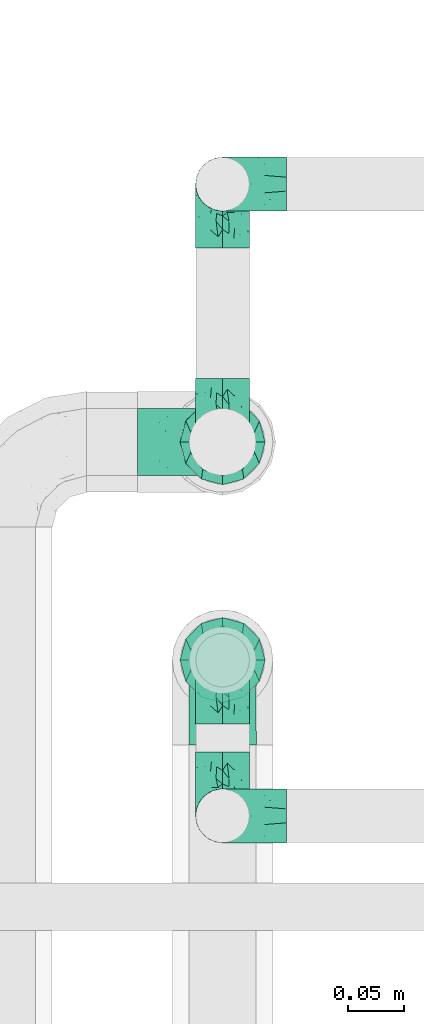
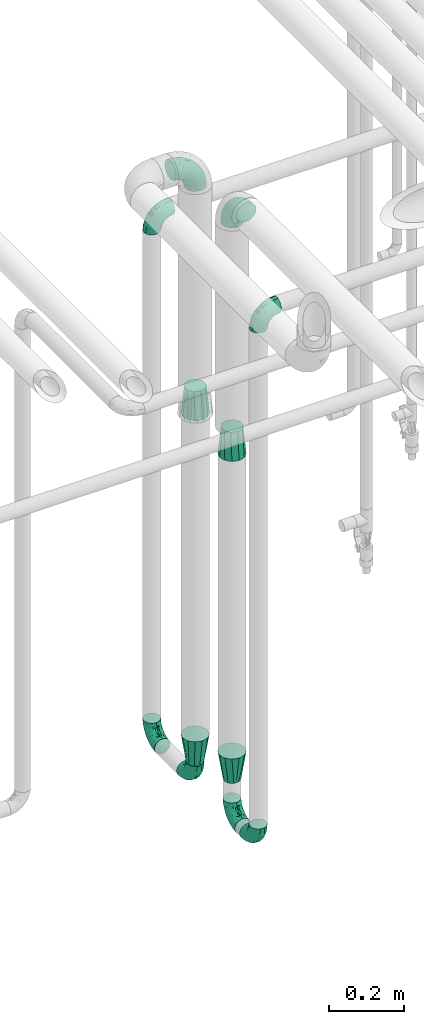
# One storey, part 576 of 827: 12 flow fittings.
"""IFC2X3 building model written with IfcOpenShell, lengths in millimetres."""

from ifc_helpers import new_model, entity, si_unit, converted_unit, derived_unit, direction, frame, origin, place, context, subcontext, project, spatial, faceted_brep, source, transform, mapped, material, type_object, type_shapes, element, save


model = new_model("IFC2X3")

# Units and contexts
model_context = context("Model", 3, precision=0.01, world=origin(), true_north=direction((6.12303176911189e-17, 1.0)))
body_context = subcontext(model_context, "Body", "Model", "MODEL_VIEW")
ifc_project = project(units=[si_unit("LENGTHUNIT", "METRE", prefix="MILLI"), si_unit("AREAUNIT", "SQUARE_METRE"), si_unit("VOLUMEUNIT", "CUBIC_METRE"), converted_unit("PLANEANGLEUNIT", "DEGREE", entity("IfcRatioMeasure", 0.0174532925199433), si_unit("PLANEANGLEUNIT", "RADIAN"), dimensions=[0, 0, 0, 0, 0, 0, 0]), si_unit("MASSUNIT", "GRAM", prefix="KILO"), derived_unit("MASSDENSITYUNIT", [(si_unit("MASSUNIT", "GRAM", prefix="KILO"), 1), (si_unit("LENGTHUNIT", "METRE"), -3)]), derived_unit("MOMENTOFINERTIAUNIT", [(si_unit("LENGTHUNIT", "METRE"), 4)]), si_unit("TIMEUNIT", "SECOND"), si_unit("FREQUENCYUNIT", "HERTZ"), si_unit("THERMODYNAMICTEMPERATUREUNIT", "DEGREE_CELSIUS"), derived_unit("THERMALTRANSMITTANCEUNIT", [(si_unit("MASSUNIT", "GRAM", prefix="KILO"), 1), (si_unit("THERMODYNAMICTEMPERATUREUNIT", "KELVIN"), -1), (si_unit("TIMEUNIT", "SECOND"), -3)]), derived_unit("VOLUMETRICFLOWRATEUNIT", [(si_unit("LENGTHUNIT", "METRE"), 3), (si_unit("TIMEUNIT", "SECOND"), -1)]), derived_unit("MASSFLOWRATEUNIT", [(si_unit("MASSUNIT", "GRAM", prefix="KILO"), 1), (si_unit("TIMEUNIT", "SECOND"), -1)]), derived_unit("ROTATIONALFREQUENCYUNIT", [(si_unit("TIMEUNIT", "SECOND"), -1)]), si_unit("ELECTRICCURRENTUNIT", "AMPERE"), si_unit("ELECTRICVOLTAGEUNIT", "VOLT"), si_unit("POWERUNIT", "WATT"), si_unit("FORCEUNIT", "NEWTON", prefix="KILO"), si_unit("ILLUMINANCEUNIT", "LUX"), si_unit("LUMINOUSFLUXUNIT", "LUMEN"), si_unit("LUMINOUSINTENSITYUNIT", "CANDELA"), derived_unit("USERDEFINED", [(si_unit("MASSUNIT", "GRAM", prefix="KILO"), -1), (si_unit("LENGTHUNIT", "METRE"), -2), (si_unit("TIMEUNIT", "SECOND"), 3), (si_unit("LUMINOUSFLUXUNIT", "LUMEN"), 1)]), derived_unit("LINEARVELOCITYUNIT", [(si_unit("LENGTHUNIT", "METRE"), 1), (si_unit("TIMEUNIT", "SECOND"), -1)]), si_unit("PRESSUREUNIT", "PASCAL"), derived_unit("USERDEFINED", [(si_unit("LENGTHUNIT", "METRE"), -2), (si_unit("MASSUNIT", "GRAM", prefix="KILO"), 1), (si_unit("TIMEUNIT", "SECOND"), -2)]), derived_unit("LINEARFORCEUNIT", [(si_unit("MASSUNIT", "GRAM", prefix="KILO"), 1), (si_unit("LENGTHUNIT", "METRE"), 1), (si_unit("TIMEUNIT", "SECOND"), -2), (si_unit("LENGTHUNIT", "METRE"), -1)]), derived_unit("PLANARFORCEUNIT", [(si_unit("MASSUNIT", "GRAM", prefix="KILO"), 1), (si_unit("LENGTHUNIT", "METRE"), 1), (si_unit("TIMEUNIT", "SECOND"), -2), (si_unit("LENGTHUNIT", "METRE"), -2)])], contexts=[model_context])

# Site, building, storey
site_placement = place(None, origin())
site = spatial("IfcSite", under=ifc_project, at=site_placement, CompositionType="ELEMENT")
building_placement = place(site_placement, origin())
building = spatial("IfcBuilding", under=site, at=building_placement, CompositionType="ELEMENT")
storey_placement = place(building_placement, frame((0.0, 0.0, 28200.0)))
storey = spatial("IfcBuildingStorey", under=building, at=storey_placement, Name="08", CompositionType="ELEMENT", Elevation=28200.0)

# Flow fittings
ifc_material = material()
pipe_fitting_type_1 = type_object("IfcPipeFittingType", Name="ADSK_1", PredefinedType="NOTDEFINED", material=ifc_material)
shared_shape_1 = source(origin(), body_context, "Body", "Brep", [
    faceted_brep([(-57.0, 12.07, -20.91), (-57.0, 6.25, -23.33), (-57.0, 0.0, -24.15), (-57.0, -6.25, -23.33), (-57.0, -12.08, -20.91), (-57.0, -17.08, -17.08), (-57.0, -20.91, -12.08), (-57.0, -23.33, -6.25), (-57.0, -24.15, 0.0), (-57.0, -23.33, 6.25), (-57.0, -20.91, 12.07), (-57.0, -17.08, 17.08), (-57.0, -12.08, 20.91), (-57.0, -6.25, 23.33), (-57.0, 0.0, 24.15), (-57.0, 6.25, 23.33), (-57.0, 12.07, 20.91), (-57.0, 17.08, 17.08), (-57.0, 20.91, 12.07), (-57.0, 23.33, 6.25), (-57.0, 24.15, 0.0), (-57.0, 23.33, -6.25), (-57.0, 20.91, -12.08), (-57.0, 17.08, -17.08), (0.0, 57.0, -24.15), (-6.25, 57.0, -23.33), (-12.07, 57.0, -20.91), (-17.08, 57.0, -17.08), (-20.91, 57.0, -12.08), (-23.33, 57.0, -6.25), (-24.15, 57.0, 0.0), (-23.33, 57.0, 6.25), (-20.91, 57.0, 12.07), (-17.08, 57.0, 17.08), (-12.07, 57.0, 20.91), (-6.25, 57.0, 23.33), (0.0, 57.0, 24.15), (6.25, 57.0, 23.33), (12.08, 57.0, 20.91), (17.08, 57.0, 17.08), (20.91, 57.0, 12.07), (23.33, 57.0, 6.25), (24.15, 57.0, 0.0), (23.33, 57.0, -6.25), (20.91, 57.0, -12.08), (17.08, 57.0, -17.08), (12.08, 57.0, -20.91), (6.25, 57.0, -23.33), (14.9, 21.14, 6.17), (13.61, 24.64, 12.48), (6.23, 8.95, 8.98), (-41.47, -21.06, 0.0), (-41.92, -18.38, 13.72), (-24.64, -13.61, 12.48), (-37.37, -13.24, 18.15), (-6.8, -4.93, 8.18), (-21.76, -15.19, 6.22), (-12.78, -9.18, 0.0), (-37.73, -20.51, 7.75), (-7.38, 7.38, 20.24), (-23.37, -4.26, 20.42), (-11.9, -3.19, 15.86), (-42.14, -8.7, 21.82), (13.24, 37.37, 18.15), (9.33, 23.53, 16.85), (4.26, 23.37, 20.42), (2.77, 10.92, 15.55), (-29.46, 0.91, 23.52), (-44.13, 20.56, 15.69), (-39.25, 26.33, 10.88), (-49.02, 22.92, 9.96), (-34.58, 23.87, 17.15), (-15.8, 6.8, 22.81), (-8.67, 20.47, 23.88), (-18.12, 12.9, 24.08), (-48.29, 14.92, 19.65), (-44.06, -2.85, 23.78), (-9.23, 48.95, 22.58), (-3.78, 42.74, 24.07), (-40.34, 4.26, 24.09), (-44.02, 26.14, 5.46), (-44.04, 9.88, 22.74), (-4.95, 16.87, 22.52), (-2.75, 1.43, 12.5), (-25.48, 40.98, 10.71), (20.51, 37.73, 7.75), (18.38, 41.92, 13.72), (8.7, 42.14, 21.82), (-25.95, -17.97, 0.0), (2.85, 44.06, 23.78), (21.06, 41.47, 0.0), (17.97, 25.95, 0.0), (-24.04, -9.27, 17.13), (-33.26, 33.26, 5.86), (-28.55, 40.57, 0.0), (-40.57, 28.55, 0.0), (-25.29, 47.19, 4.06), (-27.01, 31.1, 16.77), (-15.7, 43.95, 19.9), (-20.27, 45.22, 15.61), (-30.53, 31.98, 12.64), (-11.28, 38.33, 22.92), (-9.97, 27.88, 24.09), (-20.15, 30.26, 21.25), (-31.25, 11.75, 23.64), (-28.75, 7.23, 24.15), (-29.53, 18.06, 22.27), (-28.44, 24.21, 20.02), (-37.55, 17.7, 20.26), (-15.88, 29.25, 22.99), (-20.82, 20.82, 23.44), (-0.91, 29.46, 23.52), (-13.5, -7.67, 12.04), (1.49, 1.56, 5.16), (8.86, 10.35, 4.59), (0.38, -0.38, 0.0), (9.18, 12.78, 0.0), (-37.37, -13.24, -18.15), (8.86, 10.35, -4.59), (-45.22, 20.27, -15.61), (-43.95, 15.7, -19.9), (-38.33, 11.28, -22.92), (-48.95, 9.23, -22.58), (-47.19, 25.29, -4.06), (-33.26, 33.26, -5.86), (18.38, 41.92, -13.72), (-30.26, 20.15, -21.25), (2.85, 44.06, -23.78), (-4.26, 40.34, -24.09), (-40.98, 25.48, -10.71), (-41.92, -18.38, -13.72), (9.25, 23.5, -16.92), (4.26, 23.37, -20.42), (13.24, 37.37, -18.15), (-37.73, -20.51, -7.75), (-11.75, 31.25, -23.64), (-7.23, 28.75, -24.15), (-12.9, 18.12, -24.08), (8.7, 42.14, -21.82), (-44.06, -2.85, -23.78), (-6.8, 15.8, -22.81), (-20.47, 8.67, -23.88), (-24.64, -13.61, -12.48), (-42.74, 3.78, -24.07), (-18.06, 29.53, -22.27), (-24.21, 28.44, -20.02), (-27.88, 9.97, -24.09), (-31.1, 27.01, -16.77), (-26.14, 44.02, -5.46), (14.9, 21.14, -6.17), (20.51, 37.73, -7.75), (-9.88, 44.04, -22.74), (-20.56, 44.13, -15.69), (-21.76, -15.19, -6.22), (-13.5, -7.67, -12.04), (-24.14, -9.76, -16.74), (-11.9, -3.19, -15.86), (-14.92, 48.29, -19.65), (-23.37, -4.26, -20.42), (-0.91, 29.46, -23.52), (-26.33, 39.25, -10.88), (-23.87, 34.58, -17.15), (-42.14, -8.7, -21.82), (-22.92, 49.02, -9.96), (13.61, 24.64, -12.48), (-31.98, 30.53, -12.64), (-16.87, 4.95, -22.52), (-17.7, 37.55, -20.26), (-29.25, 15.88, -22.99), (-20.82, 20.82, -23.44), (-29.46, 0.91, -23.52), (-7.38, 7.38, -20.24), (2.77, 10.92, -15.55), (6.23, 8.95, -8.98), (-6.8, -4.93, -8.18), (-2.81, 1.41, -12.54), (1.49, 1.56, -5.16)], [[[0, 1, 2, 3, 4, 5, 6, 7, 8, 9, 10, 11, 12, 13, 14, 15, 16, 17, 18, 19, 20, 21, 22, 23]], [[24, 25, 26, 27, 28, 29, 30, 31, 32, 33, 34, 35, 36, 37, 38, 39, 40, 41, 42, 43, 44, 45, 46, 47]], [[48, 49, 50]], [[9, 8, 51]], [[52, 53, 54]], [[55, 56, 57]], [[10, 58, 52]], [[9, 58, 10]], [[59, 60, 61]], [[54, 12, 11]], [[54, 62, 12]], [[63, 39, 38]], [[64, 65, 66]], [[62, 60, 67]], [[68, 69, 70]], [[71, 69, 68]], [[72, 73, 74]], [[16, 75, 17]], [[13, 76, 14]], [[35, 77, 78]], [[14, 79, 15]], [[17, 68, 18]], [[14, 76, 79]], [[20, 19, 80]], [[70, 19, 18]], [[81, 15, 79]], [[15, 81, 16]], [[73, 72, 82]], [[66, 83, 50]], [[32, 31, 84]], [[85, 86, 49]], [[63, 87, 65]], [[56, 58, 88]], [[36, 89, 37]], [[85, 41, 40]], [[36, 35, 78]], [[90, 41, 85]], [[40, 39, 86]], [[12, 62, 13]], [[86, 85, 40]], [[48, 85, 49]], [[85, 91, 90]], [[87, 38, 37]], [[92, 60, 54]], [[80, 69, 93]], [[93, 94, 95]], [[10, 52, 11]], [[94, 96, 30]], [[97, 98, 99]], [[80, 93, 95]], [[100, 97, 84]], [[99, 98, 33]], [[101, 102, 78]], [[103, 101, 98]], [[96, 31, 30]], [[77, 98, 101]], [[77, 35, 34]], [[34, 33, 98]], [[9, 51, 58]], [[87, 63, 38]], [[104, 105, 74]], [[106, 103, 107]], [[106, 81, 104]], [[75, 68, 17]], [[108, 107, 71]], [[33, 32, 99]], [[109, 103, 110]], [[101, 109, 102]], [[89, 78, 111]], [[53, 52, 58]], [[54, 11, 52]], [[60, 62, 54]], [[88, 58, 51]], [[76, 62, 67]], [[53, 112, 92]], [[60, 59, 72]], [[39, 63, 86]], [[49, 86, 63]], [[89, 87, 37]], [[42, 41, 90]], [[111, 82, 65]], [[111, 65, 87]], [[65, 59, 66]], [[104, 81, 79]], [[75, 81, 108]], [[32, 84, 99]], [[97, 99, 84]], [[98, 97, 103]], [[106, 107, 108]], [[74, 102, 110]], [[111, 78, 102]], [[74, 110, 104]], [[74, 67, 72]], [[61, 92, 112]], [[66, 59, 61]], [[56, 53, 58]], [[66, 50, 49]], [[61, 112, 83]], [[66, 49, 64]], [[78, 89, 36]], [[87, 89, 111]], [[62, 76, 13]], [[79, 76, 67]], [[100, 93, 69]], [[96, 93, 84]], [[55, 113, 50]], [[113, 114, 50]], [[104, 79, 105]], [[106, 104, 110]], [[20, 80, 95]], [[85, 48, 91]], [[115, 114, 113]], [[116, 91, 48]], [[70, 80, 19]], [[93, 96, 94]], [[84, 31, 96]], [[103, 106, 110]], [[81, 106, 108]], [[103, 97, 107]], [[71, 107, 97]], [[71, 97, 100]], [[108, 71, 68]], [[79, 67, 105]], [[67, 74, 105]], [[115, 113, 57]], [[112, 56, 55]], [[56, 88, 57]], [[60, 72, 67]], [[82, 72, 59]], [[65, 82, 59]], [[82, 111, 73]], [[111, 102, 73]], [[102, 74, 73]], [[81, 75, 16]], [[68, 75, 108]], [[68, 70, 18]], [[80, 70, 69]], [[98, 77, 34]], [[78, 77, 101]], [[93, 100, 84]], [[71, 100, 69]], [[102, 109, 110]], [[101, 103, 109]], [[53, 92, 54]], [[61, 60, 92]], [[56, 112, 53]], [[83, 112, 55]], [[50, 83, 55]], [[61, 83, 66]], [[49, 63, 64]], [[65, 64, 63]], [[57, 113, 55]], [[114, 115, 116]], [[116, 48, 114]], [[48, 50, 114]], [[117, 5, 4]], [[116, 115, 118]], [[119, 120, 23]], [[121, 122, 120]], [[95, 123, 20]], [[0, 23, 120]], [[124, 95, 94]], [[125, 45, 44]], [[121, 120, 126]], [[24, 127, 128]], [[22, 21, 129]], [[0, 122, 1]], [[5, 117, 130]], [[131, 132, 133]], [[134, 88, 51]], [[135, 136, 137]], [[6, 5, 130]], [[46, 138, 47]], [[139, 3, 2]], [[140, 141, 137]], [[6, 134, 7]], [[134, 130, 142]], [[143, 2, 1]], [[144, 126, 145]], [[121, 146, 143]], [[147, 120, 119]], [[94, 148, 124]], [[149, 150, 91]], [[30, 29, 148]], [[151, 25, 128]], [[27, 152, 28]], [[134, 153, 88]], [[154, 155, 156]], [[27, 26, 157]], [[151, 26, 25]], [[155, 158, 156]], [[24, 47, 127]], [[1, 122, 143]], [[138, 132, 159]], [[160, 152, 161]], [[24, 128, 25]], [[46, 133, 138]], [[162, 117, 4]], [[148, 160, 124]], [[152, 160, 163]], [[154, 142, 155]], [[45, 125, 133]], [[133, 46, 45]], [[125, 164, 133]], [[51, 7, 134]], [[42, 90, 43]], [[165, 147, 129]], [[153, 134, 142]], [[43, 150, 44]], [[162, 4, 3]], [[141, 140, 166]], [[117, 162, 158]], [[163, 29, 28]], [[43, 90, 150]], [[123, 21, 20]], [[144, 151, 135]], [[157, 152, 27]], [[167, 145, 161]], [[23, 22, 119]], [[168, 126, 169]], [[121, 168, 146]], [[139, 143, 170]], [[142, 130, 117]], [[8, 7, 51]], [[134, 6, 130]], [[139, 162, 3]], [[170, 166, 158]], [[170, 158, 162]], [[158, 171, 156]], [[44, 150, 125]], [[91, 150, 90]], [[164, 125, 150]], [[132, 138, 133]], [[127, 138, 159]], [[131, 164, 172]], [[132, 171, 140]], [[135, 151, 128]], [[157, 151, 167]], [[22, 129, 119]], [[147, 119, 129]], [[120, 147, 126]], [[144, 145, 167]], [[137, 146, 169]], [[170, 143, 146]], [[137, 169, 135]], [[137, 159, 140]], [[171, 172, 156]], [[173, 174, 175]], [[156, 175, 154]], [[174, 57, 153]], [[132, 172, 171]], [[172, 164, 173]], [[143, 139, 2]], [[162, 139, 170]], [[138, 127, 47]], [[128, 127, 159]], [[165, 124, 160]], [[123, 124, 129]], [[149, 173, 164]], [[176, 174, 173]], [[135, 128, 136]], [[144, 135, 169]], [[150, 149, 164]], [[176, 118, 115]], [[149, 91, 116]], [[30, 148, 94]], [[163, 148, 29]], [[124, 123, 95]], [[129, 21, 123]], [[126, 144, 169]], [[151, 144, 167]], [[126, 147, 145]], [[161, 145, 147]], [[161, 147, 165]], [[167, 161, 152]], [[128, 159, 136]], [[159, 137, 136]], [[154, 153, 142]], [[132, 140, 159]], [[174, 176, 57]], [[57, 88, 153]], [[166, 140, 171]], [[158, 166, 171]], [[166, 170, 141]], [[170, 146, 141]], [[146, 137, 141]], [[151, 157, 26]], [[152, 157, 167]], [[152, 163, 28]], [[148, 163, 160]], [[120, 122, 0]], [[143, 122, 121]], [[124, 165, 129]], [[161, 165, 160]], [[146, 168, 169]], [[121, 126, 168]], [[142, 117, 155]], [[158, 155, 117]], [[175, 156, 172]], [[153, 154, 174]], [[173, 175, 172]], [[174, 154, 175]], [[164, 131, 133]], [[172, 132, 131]], [[176, 173, 118]], [[57, 176, 115]], [[173, 149, 118]], [[149, 116, 118]]]),
])
type_shapes(pipe_fitting_type_1, [shared_shape_1])
for number, where, z_axis, x_axis, name in (
    (1, (17922.29, 15953.09, 400.94), (-1.0, 0.0, 0.0), (0.0, 0.0, -1.0), "ADSK_1"),
    (2, (17922.29, 15387.98, 400.94), (1.0, 0.0, 0.0), (0.0, 0.0, -1.0), "ADSK_1"),
    (3, (17922.29, 15527.25, 400.94), (-1.0, 0.0, 0.0), (0.0, 0.0, -1.0), "ADSK_1"),
    (4, (17922.29, 15953.09, 2095.94), (0.0, 1.0, 0.0), (0.0, 0.0, 1.0), "ADSK_1"),
    (5, (17922.29, 15387.98, 2120.94), (0.0, 1.0, 0.0), (0.0, 0.0, 1.0), "ADSK_1"),
    (6, (17922.29, 15722.44, 400.94), (-1.0, 0.0, 0.0), (0.0, -1.0, 0.0), "ADSK_1"),
):
    element("IfcFlowFitting", number, at=place(storey_placement, frame(where, z_axis=z_axis, x_axis=x_axis)), inside=storey, type_object=pipe_fitting_type_1, material=ifc_material, Name=name, ObjectType="ADSK_1", context=body_context, shape_type="MappedRepresentation", body=[
        mapped(shared_shape_1, transform((0.0, 0.0, 0.0), scale=1.0)),
    ])
pipe_fitting_type_2 = type_object("IfcPipeFittingType", Name="ADSK_1", PredefinedType="NOTDEFINED", material=ifc_material)
shared_shape_2 = source(origin(), body_context, "Body", "Brep", [
    faceted_brep([(-76.0, 15.07, -26.11), (-76.0, 7.8, -29.12), (-76.0, 0.0, -30.15), (-76.0, -7.8, -29.12), (-76.0, -15.08, -26.11), (-76.0, -21.32, -21.32), (-76.0, -26.11, -15.08), (-76.0, -29.12, -7.8), (-76.0, -30.15, 0.0), (-76.0, -29.12, 7.8), (-76.0, -26.11, 15.07), (-76.0, -21.32, 21.32), (-76.0, -15.08, 26.11), (-76.0, -7.8, 29.12), (-76.0, 0.0, 30.15), (-76.0, 7.8, 29.12), (-76.0, 15.07, 26.11), (-76.0, 21.32, 21.32), (-76.0, 26.11, 15.07), (-76.0, 29.12, 7.8), (-76.0, 30.15, 0.0), (-76.0, 29.12, -7.8), (-76.0, 26.11, -15.08), (-76.0, 21.32, -21.32), (0.0, 76.0, -30.15), (-7.8, 76.0, -29.12), (-15.07, 76.0, -26.11), (-21.32, 76.0, -21.32), (-26.11, 76.0, -15.08), (-29.12, 76.0, -7.8), (-30.15, 76.0, 0.0), (-29.12, 76.0, 7.8), (-26.11, 76.0, 15.07), (-21.32, 76.0, 21.32), (-15.07, 76.0, 26.11), (-7.8, 76.0, 29.12), (0.0, 76.0, 30.15), (7.8, 76.0, 29.12), (15.08, 76.0, 26.11), (21.32, 76.0, 21.32), (26.11, 76.0, 15.07), (29.12, 76.0, 7.8), (30.15, 76.0, 0.0), (29.12, 76.0, -7.8), (26.11, 76.0, -15.08), (21.32, 76.0, -21.32), (15.08, 76.0, -26.11), (7.8, 76.0, -29.12), (10.79, 31.43, 21.07), (4.32, 31.7, 25.72), (1.65, 15.19, 19.92), (-61.17, -27.8, 0.0), (-51.1, -25.49, 9.84), (-56.14, -10.61, 27.27), (-31.7, -4.32, 25.72), (-39.75, 1.72, 29.41), (-43.2, -24.95, 0.0), (-1.86, 1.86, 0.0), (4.49, 7.65, 5.78), (-7.82, -4.61, 5.83), (-56.21, -22.79, 17.21), (-58.98, -3.38, 29.7), (-53.96, 5.6, 30.07), (-10.86, 10.86, 25.48), (-17.2, -2.6, 20.44), (-49.15, -16.01, 22.7), (-22.18, -14.24, 7.99), (-28.4, -17.42, 0.0), (-13.61, -9.88, 0.0), (-39.0, 23.48, 27.76), (-58.76, 12.54, 28.36), (-41.61, 15.41, 29.48), (16.01, 49.15, 22.7), (-58.55, 25.93, 19.53), (-51.53, 33.5, 13.51), (-64.92, 28.76, 12.4), (-7.48, 23.14, 28.25), (-1.72, 39.75, 29.41), (-12.04, 27.88, 29.88), (-63.91, 18.81, 24.52), (-11.63, 65.16, 28.18), (-4.97, 57.02, 30.05), (9.88, 13.61, 0.0), (-62.5, 31.74, 5.02), (-45.17, 30.98, 21.2), (-21.78, 9.76, 28.58), (10.61, 56.14, 27.27), (-32.09, 54.42, 13.26), (22.79, 56.21, 17.21), (15.38, 31.17, 15.63), (25.49, 51.1, 9.84), (21.84, 36.35, 5.92), (24.95, 43.2, 0.0), (3.38, 58.98, 29.7), (-31.17, -15.38, 15.63), (-39.39, 41.78, 15.45), (-34.56, 41.13, 20.79), (-39.81, -23.25, 5.49), (27.8, 61.17, 0.0), (-31.74, 62.5, 5.02), (-53.07, 36.29, 0.0), (-42.95, 42.95, 7.29), (-36.29, 53.07, 0.0), (-19.83, 58.51, 24.79), (-25.48, 60.2, 19.41), (-14.53, 50.96, 28.57), (-13.31, 37.09, 30.07), (-26.16, 40.06, 26.4), (-32.43, -10.35, 21.9), (17.42, 28.4, 0.0), (14.24, 22.18, 7.99), (-38.67, 9.72, 30.15), (-24.66, 17.36, 30.09), (-37.08, 31.49, 24.99), (-49.27, 22.83, 25.24), (-20.8, 38.81, 28.63), (-27.58, 27.58, 29.2), (-36.07, -20.23, 10.71), (-15.19, -6.16, 14.9), (6.6, 15.4, 14.49), (-2.51, 2.51, 11.35), (-65.16, 11.63, -28.18), (-49.15, -16.01, -22.7), (-57.02, 4.97, -30.05), (-25.93, 58.55, -19.53), (-33.5, 51.53, -13.51), (-28.76, 64.92, -12.4), (-60.2, 25.48, -19.41), (-58.51, 19.83, -24.79), (4.61, 7.82, -5.83), (-7.65, -4.49, -5.78), (-2.51, 2.51, -11.35), (-62.5, 31.74, -5.02), (-50.96, 14.53, -28.57), (-37.09, 13.31, -30.07), (-42.95, 42.95, -7.29), (25.49, 51.1, -9.84), (22.79, 56.21, -17.21), (-40.06, 26.16, -26.4), (3.38, 58.98, -29.7), (-5.6, 53.96, -30.07), (-27.88, 12.04, -29.88), (-9.76, 21.78, -28.58), (-23.14, 7.48, -28.25), (-51.1, -25.49, -9.84), (15.38, 31.17, -15.63), (16.01, 49.15, -22.7), (-23.48, 39.0, -27.76), (-12.54, 58.76, -28.36), (-15.41, 41.61, -29.48), (-56.21, -22.79, -17.21), (-9.72, 38.67, -30.15), (-17.36, 24.66, -30.09), (-22.18, -14.24, -7.99), (-41.13, 34.56, -20.79), (-31.74, 62.5, -5.02), (-58.98, -3.38, -29.7), (-31.17, -15.38, -15.63), (-56.14, -10.61, -27.27), (14.24, 22.18, -7.99), (23.25, 39.81, -5.49), (-31.49, 37.08, -24.99), (-15.19, -6.16, -14.9), (1.65, 15.19, -19.92), (-18.81, 63.91, -24.52), (-32.59, -11.62, -20.84), (-31.7, -4.32, -25.72), (-17.2, -2.6, -20.44), (-39.75, 1.72, -29.41), (-54.42, 32.09, -13.26), (-30.98, 45.17, -21.2), (10.61, 56.14, -27.27), (10.23, 31.31, -21.52), (4.32, 31.7, -25.72), (-41.78, 39.39, -15.45), (-1.72, 39.75, -29.41), (-36.35, -21.84, -5.92), (-22.83, 49.27, -25.24), (-38.81, 20.8, -28.63), (-27.58, 27.58, -29.2), (-10.86, 10.86, -25.48), (20.23, 36.07, -10.71), (6.6, 15.4, -14.49)], [[[0, 1, 2, 3, 4, 5, 6, 7, 8, 9, 10, 11, 12, 13, 14, 15, 16, 17, 18, 19, 20, 21, 22, 23]], [[24, 25, 26, 27, 28, 29, 30, 31, 32, 33, 34, 35, 36, 37, 38, 39, 40, 41, 42, 43, 44, 45, 46, 47]], [[48, 49, 50]], [[51, 52, 9]], [[53, 54, 55]], [[9, 52, 10]], [[56, 52, 51]], [[57, 58, 59]], [[11, 10, 60]], [[14, 61, 62]], [[63, 54, 64]], [[65, 12, 11]], [[65, 53, 12]], [[66, 67, 68]], [[69, 70, 71]], [[72, 39, 38]], [[73, 74, 75]], [[15, 70, 16]], [[76, 77, 78]], [[16, 79, 17]], [[13, 61, 14]], [[35, 80, 81]], [[14, 62, 15]], [[17, 73, 18]], [[57, 82, 58]], [[20, 19, 83]], [[75, 19, 18]], [[70, 15, 62]], [[73, 84, 74]], [[78, 85, 76]], [[38, 86, 72]], [[32, 31, 87]], [[88, 89, 90]], [[91, 92, 90]], [[72, 86, 49]], [[36, 93, 37]], [[75, 83, 19]], [[36, 35, 81]], [[60, 94, 65]], [[40, 90, 41]], [[95, 96, 87]], [[88, 90, 40]], [[66, 97, 67]], [[90, 98, 41]], [[40, 39, 88]], [[99, 31, 30]], [[20, 83, 100]], [[101, 102, 100]], [[52, 60, 10]], [[102, 99, 30]], [[96, 103, 104]], [[83, 101, 100]], [[12, 53, 13]], [[104, 103, 33]], [[105, 106, 81]], [[107, 105, 103]], [[64, 54, 108]], [[80, 103, 105]], [[80, 35, 34]], [[34, 33, 103]], [[86, 38, 37]], [[109, 110, 82]], [[71, 111, 112]], [[69, 107, 113]], [[79, 73, 17]], [[114, 113, 84]], [[33, 32, 104]], [[115, 107, 116]], [[105, 115, 106]], [[93, 81, 77]], [[54, 53, 65]], [[61, 53, 55]], [[108, 94, 64]], [[54, 63, 85]], [[93, 86, 37]], [[77, 76, 49]], [[77, 49, 86]], [[49, 63, 50]], [[60, 52, 117]], [[65, 11, 60]], [[39, 72, 88]], [[89, 88, 72]], [[71, 70, 62]], [[79, 70, 114]], [[103, 96, 107]], [[69, 113, 114]], [[112, 106, 116]], [[77, 81, 106]], [[112, 116, 71]], [[112, 55, 85]], [[64, 50, 63]], [[57, 59, 68]], [[32, 87, 104]], [[96, 104, 87]], [[94, 118, 64]], [[50, 119, 89]], [[50, 64, 118]], [[50, 89, 48]], [[81, 93, 36]], [[86, 93, 77]], [[53, 61, 13]], [[62, 61, 55]], [[71, 62, 111]], [[69, 71, 116]], [[95, 101, 74]], [[99, 101, 87]], [[118, 66, 59]], [[117, 97, 66]], [[117, 66, 94]], [[91, 89, 110]], [[91, 110, 109]], [[110, 89, 119]], [[9, 8, 51]], [[98, 90, 92]], [[98, 42, 41]], [[101, 83, 74]], [[101, 99, 102]], [[87, 31, 99]], [[62, 55, 111]], [[55, 112, 111]], [[107, 69, 116]], [[70, 69, 114]], [[107, 96, 113]], [[84, 113, 96]], [[84, 96, 95]], [[114, 84, 73]], [[70, 79, 16]], [[73, 79, 114]], [[54, 85, 55]], [[76, 85, 63]], [[49, 76, 63]], [[77, 106, 78]], [[106, 112, 78]], [[85, 78, 112]], [[73, 75, 18]], [[83, 75, 74]], [[103, 80, 34]], [[81, 80, 105]], [[101, 95, 87]], [[84, 95, 74]], [[106, 115, 116]], [[105, 107, 115]], [[120, 59, 58]], [[82, 110, 58]], [[119, 58, 110]], [[118, 59, 120]], [[66, 68, 59]], [[54, 65, 108]], [[94, 108, 65]], [[66, 118, 94]], [[50, 118, 120]], [[50, 120, 119]], [[119, 120, 58]], [[89, 72, 48]], [[49, 48, 72]], [[60, 117, 94]], [[117, 52, 97]], [[52, 56, 97]], [[67, 97, 56]], [[92, 91, 109]], [[89, 91, 90]], [[121, 1, 0]], [[122, 5, 4]], [[2, 1, 123]], [[124, 125, 126]], [[127, 128, 23]], [[129, 130, 131]], [[100, 132, 20]], [[133, 134, 123]], [[135, 100, 102]], [[136, 137, 44]], [[133, 128, 138]], [[24, 139, 140]], [[141, 142, 143]], [[121, 128, 133]], [[6, 144, 7]], [[137, 145, 146]], [[144, 51, 7]], [[147, 148, 149]], [[144, 6, 150]], [[149, 151, 152]], [[153, 68, 67]], [[154, 128, 127]], [[30, 155, 102]], [[43, 42, 98]], [[156, 3, 2]], [[157, 144, 150]], [[158, 4, 3]], [[24, 140, 25]], [[155, 135, 102]], [[159, 160, 109]], [[30, 29, 155]], [[147, 138, 161]], [[27, 124, 28]], [[57, 129, 82]], [[162, 163, 131]], [[27, 26, 164]], [[148, 26, 25]], [[165, 166, 167]], [[24, 47, 139]], [[143, 168, 141]], [[22, 21, 169]], [[125, 124, 170]], [[148, 25, 140]], [[46, 146, 171]], [[158, 122, 4]], [[0, 23, 128]], [[1, 121, 123]], [[109, 82, 159]], [[45, 44, 137]], [[146, 46, 45]], [[136, 43, 98]], [[132, 21, 20]], [[136, 98, 92]], [[172, 173, 146]], [[46, 171, 47]], [[43, 136, 44]], [[174, 154, 169]], [[171, 173, 175]], [[6, 5, 150]], [[126, 29, 28]], [[176, 56, 144]], [[122, 158, 166]], [[164, 124, 27]], [[177, 161, 170]], [[23, 22, 127]], [[178, 138, 179]], [[133, 178, 134]], [[156, 123, 168]], [[156, 158, 3]], [[168, 143, 166]], [[168, 166, 158]], [[166, 180, 167]], [[173, 171, 146]], [[139, 171, 175]], [[172, 145, 163]], [[173, 180, 142]], [[5, 122, 150]], [[157, 150, 122]], [[137, 136, 181]], [[146, 45, 137]], [[149, 148, 140]], [[164, 148, 177]], [[128, 154, 138]], [[147, 161, 177]], [[152, 134, 179]], [[168, 123, 134]], [[152, 179, 149]], [[152, 175, 142]], [[57, 130, 129]], [[157, 165, 167]], [[22, 169, 127]], [[154, 127, 169]], [[163, 167, 180]], [[162, 157, 167]], [[173, 163, 180]], [[182, 163, 145]], [[123, 156, 2]], [[158, 156, 168]], [[171, 139, 47]], [[140, 139, 175]], [[149, 140, 151]], [[147, 149, 179]], [[174, 135, 125]], [[132, 135, 169]], [[176, 157, 153]], [[176, 153, 67]], [[153, 157, 162]], [[182, 159, 129]], [[181, 160, 159]], [[181, 159, 145]], [[51, 144, 56]], [[51, 8, 7]], [[135, 132, 100]], [[169, 21, 132]], [[126, 155, 29]], [[135, 155, 125]], [[140, 175, 151]], [[175, 152, 151]], [[138, 147, 179]], [[148, 147, 177]], [[138, 154, 161]], [[170, 161, 154]], [[170, 154, 174]], [[177, 170, 124]], [[148, 164, 26]], [[124, 164, 177]], [[173, 142, 175]], [[143, 142, 180]], [[166, 143, 180]], [[168, 134, 141]], [[134, 152, 141]], [[142, 141, 152]], [[124, 126, 28]], [[155, 126, 125]], [[128, 121, 0]], [[123, 121, 133]], [[135, 174, 169]], [[170, 174, 125]], [[134, 178, 179]], [[133, 138, 178]], [[130, 153, 162]], [[68, 153, 130]], [[57, 68, 130]], [[182, 129, 131]], [[159, 82, 129]], [[157, 122, 165]], [[166, 165, 122]], [[163, 162, 167]], [[162, 131, 130]], [[145, 172, 146]], [[163, 173, 172]], [[159, 182, 145]], [[131, 163, 182]], [[56, 176, 67]], [[157, 176, 144]], [[137, 181, 145]], [[181, 136, 160]], [[136, 92, 160]], [[109, 160, 92]]]),
])
type_shapes(pipe_fitting_type_2, [shared_shape_2])
for number, where, z_axis, x_axis, name in (
    (7, (17922.29, 15722.44, 2400.16), (0.0, -1.0, 0.0), (0.0, 0.0, 1.0), "ADSK_1"),
    (8, (17922.29, 15527.25, 2400.0), (1.0, 0.0, 0.0), (0.0, 0.0, 1.0), "ADSK_1"),
):
    element("IfcFlowFitting", number, at=place(storey_placement, frame(where, z_axis=z_axis, x_axis=x_axis)), inside=storey, type_object=pipe_fitting_type_2, material=ifc_material, Name=name, ObjectType="ADSK_1", context=body_context, shape_type="MappedRepresentation", body=[
        mapped(shared_shape_2, transform((0.0, 0.0, 0.0), scale=1.0)),
    ])
pipe_fitting_type_3 = type_object("IfcPipeFittingType", Name="ADSK_1", PredefinedType="NOTDEFINED", material=ifc_material)
shared_shape_3 = source(origin(), body_context, "Body", "Brep", [
    faceted_brep([(89.0, -38.05, 0.0), (89.0, -36.21, -6.85), (89.0, -32.95, -19.02), (89.0, -25.99, -25.99), (89.0, -19.03, -32.95), (89.0, -9.51, -35.5), (89.0, 0.0, -38.05), (89.0, 9.51, -35.5), (89.0, 19.02, -32.95), (89.0, 25.99, -25.99), (89.0, 32.95, -19.02), (89.0, 36.21, -6.85), (89.0, 38.05, 0.0), (89.0, 36.21, 6.85), (89.0, 32.95, 19.03), (89.0, 25.99, 25.99), (89.0, 19.02, 32.95), (89.0, 9.51, 35.5), (89.0, 0.0, 38.05), (89.0, -9.51, 35.5), (89.0, -19.03, 32.95), (89.0, -25.99, 25.99), (89.0, -32.95, 19.03), (89.0, -36.21, 6.85), (0.0, 24.15, 0.0), (0.0, 21.84, -7.1), (0.0, 19.54, -14.2), (0.0, 13.5, -18.58), (0.0, 7.46, -22.97), (0.0, 0.0, -22.97), (0.0, -7.46, -22.97), (0.0, -13.5, -18.58), (0.0, -19.54, -14.2), (0.0, -21.84, -7.1), (0.0, -24.15, 0.0), (0.0, -21.84, 7.1), (0.0, -19.54, 14.2), (0.0, -13.5, 18.58), (0.0, -7.46, 22.97), (0.0, 0.0, 22.97), (0.0, 7.46, 22.97), (0.0, 13.5, 18.58), (0.0, 19.54, 14.2), (0.0, 21.84, 7.1)], [[[0, 1, 2, 3, 4, 5, 6, 7, 8, 9, 10, 11, 12, 13, 14, 15, 16, 17, 18, 19, 20, 21, 22, 23]], [[24, 25, 26, 27, 28, 29, 30, 31, 32, 33, 34, 35, 36, 37, 38, 39, 40, 41, 42, 43]], [[2, 33, 32]], [[28, 7, 29]], [[29, 5, 30]], [[24, 12, 11]], [[3, 32, 31]], [[34, 1, 0]], [[1, 34, 33]], [[8, 28, 27]], [[2, 1, 33]], [[31, 4, 3]], [[2, 32, 3]], [[11, 25, 24]], [[26, 10, 9]], [[10, 25, 11]], [[28, 8, 7]], [[27, 26, 9]], [[26, 25, 10]], [[31, 30, 4]], [[8, 27, 9]], [[29, 7, 6]], [[5, 29, 6]], [[5, 4, 30]], [[14, 43, 42]], [[38, 19, 39]], [[39, 17, 40]], [[34, 0, 23]], [[15, 42, 41]], [[24, 13, 12]], [[13, 24, 43]], [[20, 38, 37]], [[14, 13, 43]], [[41, 16, 15]], [[14, 42, 15]], [[23, 35, 34]], [[36, 22, 21]], [[22, 35, 23]], [[38, 20, 19]], [[37, 36, 21]], [[36, 35, 22]], [[41, 40, 16]], [[20, 37, 21]], [[39, 19, 18]], [[17, 39, 18]], [[17, 16, 40]]]),
])
type_shapes(pipe_fitting_type_3, [shared_shape_3])
for number, where, z_axis, x_axis, name in (
    (9, (17922.29, 15527.25, 520.94), (0.0, -1.0, 0.0), (0.0, 0.0, 1.0), "ADSK_1"),
    (10, (17922.29, 15722.44, 457.94), (-1.0, 0.0, 0.0), (0.0, 0.0, 1.0), "ADSK_1"),
):
    element("IfcFlowFitting", number, at=place(storey_placement, frame(where, z_axis=z_axis, x_axis=x_axis)), inside=storey, type_object=pipe_fitting_type_3, material=ifc_material, Name=name, ObjectType="ADSK_1", context=body_context, shape_type="MappedRepresentation", body=[
        mapped(shared_shape_3, transform((0.0, 0.0, 0.0), scale=1.0)),
    ])
pipe_fitting_type_4 = type_object("IfcPipeFittingType", Name="ADSK_1", PredefinedType="NOTDEFINED", material=ifc_material)
shared_shape_4 = source(origin(), body_context, "Body", "Brep", [
    faceted_brep([(89.0, 24.39, -17.72), (89.0, 27.27, -8.86), (89.0, 30.15, 0.0), (89.0, 27.27, 8.86), (89.0, 24.39, 17.72), (89.0, 16.85, 23.2), (89.0, 9.32, 28.67), (89.0, 0.0, 28.67), (89.0, -9.32, 28.67), (89.0, -16.85, 23.2), (89.0, -24.39, 17.72), (89.0, -27.27, 8.86), (89.0, -30.15, 0.0), (89.0, -27.27, -8.86), (89.0, -24.39, -17.72), (89.0, -16.85, -23.2), (89.0, -9.32, -28.67), (89.0, 0.0, -28.67), (89.0, 9.32, -28.67), (89.0, 16.85, -23.2), (0.0, 38.05, 0.0), (0.0, 36.11, -7.24), (0.0, 32.95, -19.03), (0.0, 25.99, -25.99), (0.0, 19.02, -32.95), (0.0, 9.51, -35.5), (0.0, 0.0, -38.05), (0.0, -9.51, -35.5), (0.0, -19.03, -32.95), (0.0, -25.99, -25.99), (0.0, -32.95, -19.02), (0.0, -36.11, -7.24), (0.0, -38.05, 0.0), (0.0, -36.11, 7.24), (0.0, -32.95, 19.02), (0.0, -25.99, 25.99), (0.0, -19.02, 32.95), (0.0, -9.51, 35.5), (0.0, 0.0, 38.05), (0.0, 9.51, 35.5), (0.0, 19.02, 32.95), (0.0, 25.99, 25.99), (0.0, 32.95, 19.02), (0.0, 36.11, 7.24)], [[[0, 1, 2, 3, 4, 5, 6, 7, 8, 9, 10, 11, 12, 13, 14, 15, 16, 17, 18, 19]], [[20, 21, 22, 23, 24, 25, 26, 27, 28, 29, 30, 31, 32, 33, 34, 35, 36, 37, 38, 39, 40, 41, 42, 43]], [[30, 13, 31]], [[19, 18, 24]], [[19, 23, 0]], [[22, 1, 0]], [[21, 2, 1]], [[28, 16, 15]], [[23, 19, 24]], [[22, 0, 23]], [[16, 27, 17]], [[18, 17, 25]], [[14, 29, 15]], [[25, 24, 18]], [[27, 26, 17]], [[12, 31, 13]], [[22, 21, 1]], [[16, 28, 27]], [[2, 21, 20]], [[13, 30, 14]], [[14, 30, 29]], [[12, 32, 31]], [[28, 15, 29]], [[25, 17, 26]], [[42, 3, 43]], [[9, 8, 36]], [[9, 35, 10]], [[34, 11, 10]], [[33, 12, 11]], [[40, 6, 5]], [[35, 9, 36]], [[34, 10, 35]], [[6, 39, 7]], [[8, 7, 37]], [[4, 41, 5]], [[37, 36, 8]], [[39, 38, 7]], [[2, 43, 3]], [[34, 33, 11]], [[6, 40, 39]], [[12, 33, 32]], [[3, 42, 4]], [[4, 42, 41]], [[2, 20, 43]], [[40, 5, 41]], [[37, 7, 38]]]),
])
type_shapes(pipe_fitting_type_4, [shared_shape_4])
for number, where, z_axis, x_axis, name in (
    (11, (17922.29, 15527.25, 1573.32), (-1.0, 0.0, 0.0), (0.0, 0.0, 1.0), "ADSK_1"),
    (12, (17922.29, 15722.23, 1586.32), (-1.0, 0.0, 0.0), (0.0, 0.0, 1.0), "ADSK_1"),
):
    element("IfcFlowFitting", number, at=place(storey_placement, frame(where, z_axis=z_axis, x_axis=x_axis)), inside=storey, type_object=pipe_fitting_type_4, material=ifc_material, Name=name, ObjectType="ADSK_1", context=body_context, shape_type="MappedRepresentation", body=[
        mapped(shared_shape_4, transform((0.0, 0.0, 0.0), scale=1.0)),
    ])

save(model, "model.ifc")
